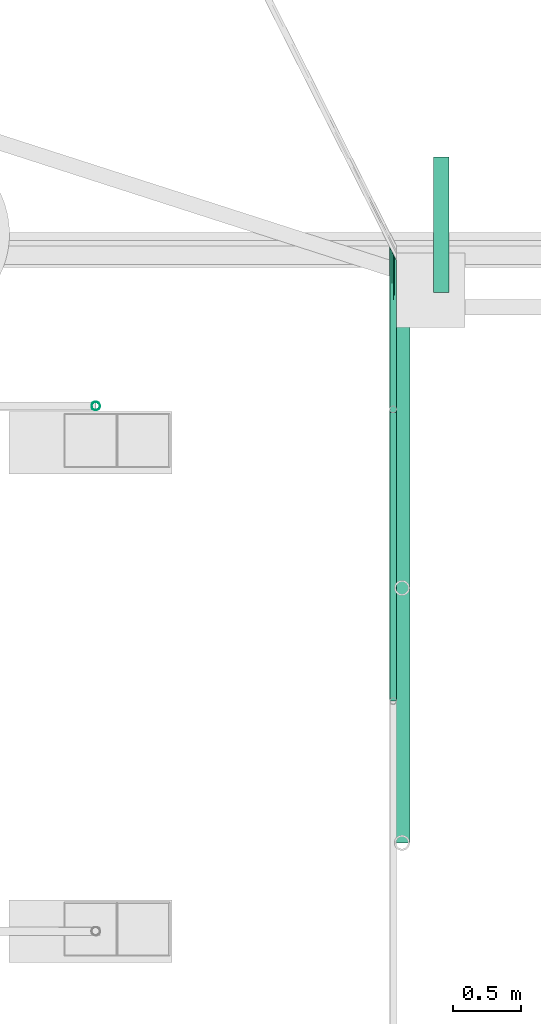
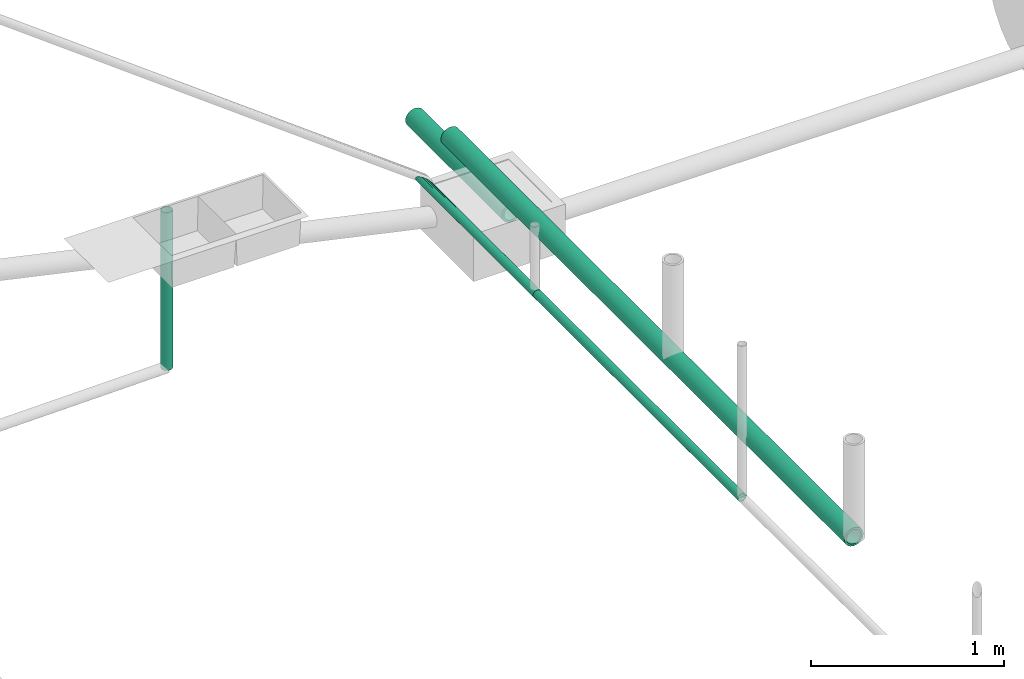
# One storey, part 5 of 15: 5 pipe segments.
"""IFC4X3_ADD2 building model written with IfcOpenShell, lengths in metres."""

import ifcopenshell
import ifcopenshell.guid

model = None  # the IFC model being written
_history = None  # IfcOwnerHistory: only IFC2X3 demands one
_inside = {}  # id of a spatial element -> (the spatial element, [elements in it])
_under = {}  # id of a project, library or spatial element -> (it, [spatial elements below it])
_declared = {}  # id of a project -> (the project, [libraries it declares])
_typed = {}  # id of a type object -> (the type object, [elements of that type])
_made_of = {}  # id of a material, layer set ... -> (it, [elements and type objects made of it])


def new_model(schema):
    """Start an empty IFC model of exactly this schema.

    Asked for "IFC4X3", IfcOpenShell would pick the latest addendum, in which some entities
    have other attributes; the version numbers below select the first issue.
    IFC2X3 requires an IfcOwnerHistory on every rooted entity: one is made here for all.
    """
    global model, _history
    if schema == "IFC4X3":
        model = ifcopenshell.file(schema_version=(4, 3, 0, 0))
    else:
        model = ifcopenshell.file(schema=schema)
    _inside.clear()
    _under.clear()
    _declared.clear()
    _typed.clear()
    _made_of.clear()
    _history = None
    if model.schema == "IFC2X3":
        org = make("IfcOrganization", Name="unknown")
        user = make(
            "IfcPersonAndOrganization",
            ThePerson=make("IfcPerson", FamilyName="unknown"),
            TheOrganization=org,
        )
        app = make(
            "IfcApplication",
            ApplicationDeveloper=org,
            Version="unknown",
            ApplicationFullName="unknown",
            ApplicationIdentifier="unknown",
        )
        _history = make(
            "IfcOwnerHistory",
            OwningUser=user,
            OwningApplication=app,
            ChangeAction="ADDED",
            CreationDate=0,
        )
    return model


def make(cls, **values):
    """One entity of the class cls with the attributes given. An attribute that is None is left unset."""
    return model.create_entity(
        cls, **{name: value for name, value in values.items() if value is not None}
    )


def entity(cls, *values):
    """Any entity or typed value of the class cls, its attributes in the order of the schema. None: left unset."""
    e = model.create_entity(cls)
    for i, value in enumerate(values):
        if value is not None:
            e[i] = value
    return e


def rooted(cls, **values):
    """An entity with a GlobalId (a new one), such as an element, a storey or a relation."""
    return make(cls, GlobalId=ifcopenshell.guid.new(), OwnerHistory=_history, **values)


def si_unit(unit_type, name, prefix=None):
    """IfcSIUnit, for example si_unit("LENGTHUNIT", "METRE", prefix="MILLI")."""
    return make("IfcSIUnit", UnitType=unit_type, Prefix=prefix, Name=name)


def converted_unit(unit_type, name, factor, base, dimensions=None, offset=None):
    """IfcConversionBasedUnit, such as the inch: factor (a typed value) times the base unit."""
    return make(
        "IfcConversionBasedUnit"
        if offset is None
        else "IfcConversionBasedUnitWithOffset",
        ConversionOffset=offset,
        Dimensions=None
        if dimensions is None
        else entity("IfcDimensionalExponents", *dimensions),
        UnitType=unit_type,
        Name=name,
        ConversionFactor=make(
            "IfcMeasureWithUnit", ValueComponent=factor, UnitComponent=base
        ),
    )


def assignment(units):
    """IfcUnitAssignment: the units of a project."""
    return None if units is None else make("IfcUnitAssignment", Units=units)


def point(xyz):
    """IfcCartesianPoint."""
    return None if xyz is None else make("IfcCartesianPoint", Coordinates=xyz)


def direction(xyz):
    """IfcDirection."""
    return None if xyz is None else make("IfcDirection", DirectionRatios=xyz)


def frame(location, z_axis=None, x_axis=None):
    """IfcAxis2Placement3D, a coordinate frame: its origin and axes. An axis left out is left unset."""
    return make(
        "IfcAxis2Placement3D",
        Location=point(location),
        Axis=direction(z_axis),
        RefDirection=direction(x_axis),
    )


def frame_2d(location, x_axis=None):
    """IfcAxis2Placement2D, a coordinate frame in the plane: its origin and x axis."""
    return make(
        "IfcAxis2Placement2D", Location=point(location), RefDirection=direction(x_axis)
    )


def origin_with_axes():
    """The frame at (0, 0, 0) with the z axis (0, 0, 1) and the x axis (1, 0, 0) written out."""
    return frame((0.0, 0.0, 0.0), z_axis=(0.0, 0.0, 1.0), x_axis=(1.0, 0.0, 0.0))


def origin_2d_with_axis():
    """The frame at (0, 0) in the plane with the x axis (1, 0) written out."""
    return frame_2d((0.0, 0.0), x_axis=(1.0, 0.0))


def place(relative_to, where):
    """IfcLocalPlacement: puts the frame where relative to a parent placement (None: the world)."""
    return make(
        "IfcLocalPlacement", PlacementRelTo=relative_to, RelativePlacement=where
    )


def context(
    kind, dimensions, precision=None, world=None, true_north=None, identifier=None
):
    """IfcGeometricRepresentationContext, for example the 3D "Model" context."""
    return make(
        "IfcGeometricRepresentationContext",
        ContextIdentifier=identifier,
        ContextType=kind,
        CoordinateSpaceDimension=dimensions,
        Precision=precision,
        WorldCoordinateSystem=world,
        TrueNorth=true_north,
    )


def subcontext(parent, identifier, kind, view, scale=None):
    """IfcGeometricRepresentationSubContext, for example "Body" below "Model"."""
    return make(
        "IfcGeometricRepresentationSubContext",
        ContextIdentifier=identifier,
        ContextType=kind,
        ParentContext=parent,
        TargetScale=scale,
        TargetView=view,
    )


def project(units=None, contexts=None):
    """IfcProject with its units and contexts."""
    return rooted(
        "IfcProject",
        Name="project",
        RepresentationContexts=contexts,
        UnitsInContext=assignment(units),
    )


def spatial(cls, under=None, at=None, **own):
    """A site, building, storey or space (cls), placed at a placement, below another one or the project."""
    s = rooted(cls, ObjectPlacement=at, **own)
    if under is not None:
        _under.setdefault(under.id(), (under, []))[1].append(s)
    return s


def profile(cls, at=None, kind="AREA", **sizes):
    """A parametric profile (cls). Its sizes go by their IFC names, for example OverallWidth=200.0."""
    return make(cls, ProfileType=kind, Position=at, **sizes)


def hollow_circle(**sizes):
    """IfcCircleHollowProfileDef."""
    return profile("IfcCircleHollowProfileDef", **sizes)


def extrude(swept, where, along, depth):
    """IfcExtrudedAreaSolid: the profile swept, set in the frame where, extruded along a direction by depth."""
    return make(
        "IfcExtrudedAreaSolid",
        SweptArea=swept,
        Position=where,
        ExtrudedDirection=direction(along),
        Depth=depth,
    )


def clip(a, b, op="DIFFERENCE"):
    """IfcBooleanClippingResult: the solid a cut by the half space b."""
    return make(
        "IfcBooleanClippingResult", Operator=op, FirstOperand=a, SecondOperand=b
    )


def halfspace(plane, agree):
    """IfcHalfSpaceSolid: all space on one side of the plane z = 0 of the frame plane."""
    return make(
        "IfcHalfSpaceSolid",
        BaseSurface=make("IfcPlane", Position=plane),
        AgreementFlag=agree,
    )


def shape(context_of_items, identifier, shape_type, items):
    """IfcShapeRepresentation: the items that make up one representation, for example the "Body"."""
    return make(
        "IfcShapeRepresentation",
        ContextOfItems=context_of_items,
        RepresentationIdentifier=identifier,
        RepresentationType=shape_type,
        Items=items,
    )


def material(Name=None, Category=None):
    """IfcMaterial."""
    return make("IfcMaterial", Name=Name, Category=Category)


def material_profile(
    of_material, cross_section, Name=None, Category=None, Priority=None
):
    """IfcMaterialProfile: a cross section and its material."""
    return make(
        "IfcMaterialProfile",
        Name=Name,
        Material=of_material,
        Profile=cross_section,
        Priority=Priority,
        Category=Category,
    )


def profile_set(profiles, Name=None, composite=None):
    """IfcMaterialProfileSet."""
    return make(
        "IfcMaterialProfileSet",
        Name=Name,
        MaterialProfiles=profiles,
        CompositeProfile=composite,
    )


def profile_usage(for_profile_set, cardinal=None, extent=None):
    """IfcMaterialProfileSetUsage: how a profile set lies along its element."""
    return make(
        "IfcMaterialProfileSetUsage",
        ForProfileSet=for_profile_set,
        CardinalPoint=cardinal,
        ReferenceExtent=extent,
    )


def made_of(thing, what):
    """Note that an element or type object is made of a material, layer set ...; save() writes the relation."""
    if what is not None:
        _made_of.setdefault(what.id(), (what, []))[1].append(thing)
    return thing


def type_object(cls, material=None, **own):
    """A type object (cls), such as IfcWallType, which elements share."""
    return made_of(rooted(cls, **own), material)


def element(
    cls,
    number,
    at=None,
    inside=None,
    cuts=None,
    type_object=None,
    material=None,
    context=None,
    identifier="Body",
    shape_type=None,
    held_by="IfcProductDefinitionShape",
    body=None,
    shapes=None,
    **own,
):
    """One element of the class cls, such as IfcWall. Its Tag is "e" and its number.

    at: its placement. inside: the storey or other place that contains it. cuts: it is an
    opening in that element (IfcRelVoidsElement). A single representation is given by context,
    identifier, shape_type and body (its items); several are given by shapes. held_by: the class
    of the entity that holds the representations. save() writes the other relations.
    """
    e = rooted(cls, Tag="e%d" % number, ObjectPlacement=at, **own)
    if body is not None:
        shapes = [shape(context, identifier, shape_type, body)]
    if shapes is not None:
        e.Representation = make(held_by, Representations=shapes)
    if inside is not None:
        _inside.setdefault(inside.id(), (inside, []))[1].append(e)
    if cuts is not None:
        rooted(
            "IfcRelVoidsElement", RelatingBuildingElement=cuts, RelatedOpeningElement=e
        )
    if type_object is not None:
        _typed.setdefault(type_object.id(), (type_object, []))[1].append(e)
    return made_of(e, material)


def aggregate(whole, parts):
    """IfcRelAggregates: a whole, such as a stair, and the parts it consists of."""
    return rooted("IfcRelAggregates", RelatingObject=whole, RelatedObjects=parts)


def save(model, path):
    """Write the relations noted so far, then the file.

    IfcRelAggregates (storeys below a building ...), IfcRelContainedInSpatialStructure (elements
    in a storey), IfcRelDefinesByType, IfcRelAssociatesMaterial and IfcRelDeclares: one each for
    every whole, place, type object, material and project.
    """
    for whole, parts in _under.values():
        aggregate(whole, parts)
    for where, things in _inside.values():
        rooted(
            "IfcRelContainedInSpatialStructure",
            RelatedElements=things,
            RelatingStructure=where,
        )
    for kind, things in _typed.values():
        rooted("IfcRelDefinesByType", RelatedObjects=things, RelatingType=kind)
    for what, things in _made_of.values():
        rooted("IfcRelAssociatesMaterial", RelatedObjects=things, RelatingMaterial=what)
    for by, libraries in _declared.values():
        rooted("IfcRelDeclares", RelatingContext=by, RelatedDefinitions=libraries)
    model.write(path)


model = new_model("IFC4X3_ADD2")

# Units and contexts
model_context = context("Model", 3, precision=1e-05, world=origin_with_axes())
plan_context = context("Plan", 2, precision=1e-05, world=origin_2d_with_axis())
body_context = subcontext(model_context, "Body", "Model", "MODEL_VIEW")
ifc_project = project(units=[si_unit("VOLUMEUNIT", "CUBIC_METRE"), si_unit("LENGTHUNIT", "METRE"), converted_unit("PLANEANGLEUNIT", "degree", entity("IfcReal", 0.0174532925199433), si_unit("PLANEANGLEUNIT", "RADIAN"), dimensions=[0, 0, 0, 0, 0, 0, 0]), si_unit("AREAUNIT", "SQUARE_METRE")], contexts=[model_context, plan_context])

# Site, building, storey
site_placement = place(None, origin_with_axes())
site = spatial("IfcSite", under=ifc_project, at=site_placement)
building_placement = place(site_placement, origin_with_axes())
building = spatial("IfcBuilding", under=site, at=building_placement, Name="Building")
storey_placement = place(building_placement, origin_with_axes())
storey = spatial("IfcBuildingStorey", under=building, at=storey_placement, Name="Plumbing")

# Pipe segments
ifc_material_1 = material()
ifc_material_profile_1 = material_profile(ifc_material_1, hollow_circle(Radius=0.0571499988436699, WallThickness=0.012699999846518))
ifc_profile_set_1 = profile_set([ifc_material_profile_1])
ifc_profile_usage_1 = profile_usage(ifc_profile_set_1)
pipe_segment_type_1 = type_object("IfcPipeSegmentType", Name="4inch Tank", PredefinedType="FLEXIBLESEGMENT", material=ifc_profile_set_1)
pipe_segment_1_placement = place(storey_placement, frame((9.20528697967529, 22.9011688232422, 0.387610822916031), z_axis=(8.74228121006121e-08, 0.999999999999993, 7.54979012640428e-08), x_axis=(-0.999999999999921, 8.74227765734689e-08, 3.89414424262182e-07)))
element("IfcPipeSegment", 1, at=pipe_segment_1_placement, inside=storey, type_object=pipe_segment_type_1, material=ifc_profile_usage_1, Name="PipeSegment", PredefinedType="FLEXIBLESEGMENT", context=body_context, shape_type="SweptSolid", body=[
    extrude(hollow_circle(Radius=0.0571499988436699, WallThickness=0.012699999846518), origin_with_axes(), (0.0, 0.0, 1.0), 4.18838491626393),
])
ifc_profile_usage_2 = profile_usage(ifc_profile_set_1)
pipe_segment_2_placement = place(storey_placement, frame((9.49463367462158, 26.9592533111572, -0.122552126646042), z_axis=(8.74228121006121e-08, 0.999999999999993, 7.54979012640428e-08), x_axis=(-0.999999999999921, 8.74227765734689e-08, 3.89414424262182e-07)))
element("IfcPipeSegment", 2, at=pipe_segment_2_placement, inside=storey, type_object=pipe_segment_type_1, material=ifc_profile_usage_2, Name="PipeSegment", PredefinedType="FLEXIBLESEGMENT", context=body_context, shape_type="SweptSolid", body=[
    extrude(hollow_circle(Radius=0.0571499988436699, WallThickness=0.012699999846518), origin_with_axes(), (0.0, 0.0, 1.0), 1.0),
])
ifc_material_2 = material(Name="Wall")
ifc_material_profile_2 = material_profile(ifc_material_2, hollow_circle(Radius=0.0253999996930361, WallThickness=0.0020000000949949))
ifc_profile_set_2 = profile_set([ifc_material_profile_2])
ifc_profile_usage_3 = profile_usage(ifc_profile_set_2)
ifc_material_profile_3 = material_profile(ifc_material_2, hollow_circle(Radius=0.0253999996930361, WallThickness=0.0020000000949949))
ifc_profile_set_3 = profile_set([ifc_material_profile_3])
pipe_segment_type_2 = type_object("IfcPipeSegmentType", Name="2inch-bath outlet", PredefinedType="FLEXIBLESEGMENT", material=ifc_profile_set_3)
pipe_segment_3_placement = place(storey_placement, frame((9.13959503173828, 26.0741424560547, 0.0252151470631361), z_axis=(-1.50995774106375e-07, 0.999999999999986, 7.54979012640422e-08), x_axis=(-0.999999999999913, -1.50995802528073e-07, 3.89414424262179e-07)))
element("IfcPipeSegment", 3, at=pipe_segment_3_placement, inside=storey, type_object=pipe_segment_type_2, material=ifc_profile_usage_3, Name="PipeSegment", context=body_context, shape_type="Clipping", body=[
    clip(extrude(hollow_circle(Radius=0.0253999996930361, WallThickness=0.0020000000949949), origin_with_axes(), (0.0, 0.0, 1.0), 1.22252846924567), halfspace(frame((-0.0256579350680113, -8.03790953796124e-08, 1.12099123001099), z_axis=(-0.892385184764862, -7.39928225357289e-08, 0.451274544000626), x_axis=(-8.2915789951427e-08, 0.999999999999997, 0.0)), False)),
])
ifc_profile_usage_4 = profile_usage(ifc_profile_set_2)
pipe_segment_4_placement = place(storey_placement, frame((9.13959503173828, 23.9477500915527, 0.0252149868756533), z_axis=(-1.50995774106375e-07, 0.999999999999986, 7.54979012640422e-08), x_axis=(-0.999999999999913, -1.50995802528073e-07, 3.89414424262179e-07)))
element("IfcPipeSegment", 4, at=pipe_segment_4_placement, inside=storey, type_object=pipe_segment_type_2, material=ifc_profile_usage_4, Name="PipeSegment", context=body_context, shape_type="SweptSolid", body=[
    extrude(hollow_circle(Radius=0.0253999996930361, WallThickness=0.0020000000949949), origin_with_axes(), (0.0, 0.0, 1.0), 2.15160754675399),
])
ifc_material_profile_4 = material_profile(ifc_material_1, hollow_circle(Radius=0.031750001013279, WallThickness=0.0020000000949949))
ifc_profile_set_4 = profile_set([ifc_material_profile_4])
ifc_profile_usage_5 = profile_usage(ifc_profile_set_4)
ifc_material_profile_5 = material_profile(ifc_material_1, hollow_circle(Radius=0.031750001013279, WallThickness=0.0020000000949949))
ifc_profile_set_5 = profile_set([ifc_material_profile_5])
pipe_segment_type_3 = type_object("IfcPipeSegmentType", Name="2.5inch- Kitchen Outlet", PredefinedType="FLEXIBLESEGMENT", material=ifc_profile_set_5)
pipe_segment_5_placement = place(storey_placement, frame((6.9461817741394, 26.1231498718262, 0.299132347106934), z_axis=(0.0, 0.0, 1.0), x_axis=(-2.82129974493717e-07, -0.99999999999996, 0.0)))
element("IfcPipeSegment", 5, at=pipe_segment_5_placement, inside=storey, type_object=pipe_segment_type_3, material=ifc_profile_usage_5, Name="PipeSegment", context=body_context, shape_type="SweptSolid", body=[
    extrude(hollow_circle(Radius=0.031750001013279, WallThickness=0.0020000000949949), origin_with_axes(), (0.0, 0.0, 1.0), 0.999999940861015),
])

save(model, "model.ifc")
